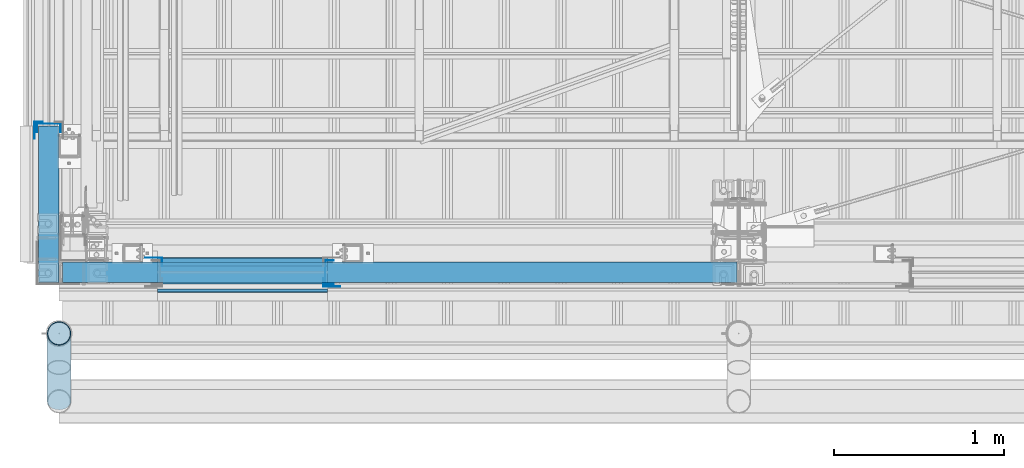
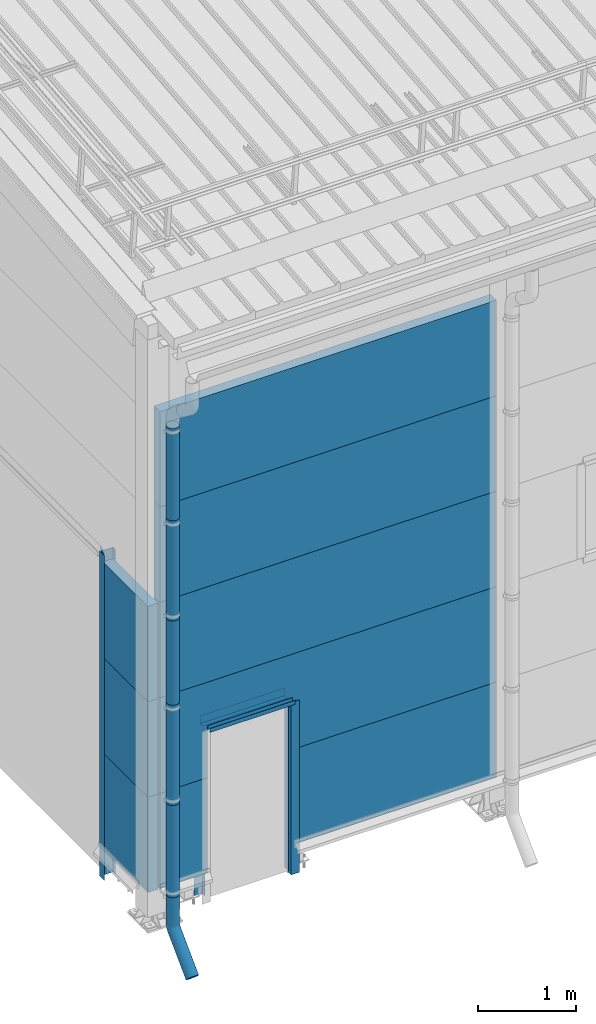
# One storey, part 28 of 709: 23 beams, 1 opening, 23 elements without a shape of their own.
"""IFC4 building model written with IfcOpenShell, lengths in millimetres."""

from ifc_helpers import new_model, entity, si_unit, direction, frame, origin_with_axes, place, context, subcontext, project, spatial, line, indexed_curve, outline, extrude, material, element, aggregate, save


model = new_model("IFC4")

# Units and contexts
model_context = context("Model", 3, precision=0.2, world=origin_with_axes(), true_north=direction((0.0, 1.0)))
body_context = subcontext(model_context, "Body", "Model", "MODEL_VIEW")
ifc_project = project(units=[si_unit("LENGTHUNIT", "METRE", prefix="MILLI"), si_unit("AREAUNIT", "SQUARE_METRE"), si_unit("VOLUMEUNIT", "CUBIC_METRE"), si_unit("MASSUNIT", "GRAM", prefix="KILO"), si_unit("TIMEUNIT", "SECOND"), si_unit("PLANEANGLEUNIT", "RADIAN"), si_unit("SOLIDANGLEUNIT", "STERADIAN"), si_unit("THERMODYNAMICTEMPERATUREUNIT", "DEGREE_CELSIUS"), si_unit("LUMINOUSINTENSITYUNIT", "LUMEN")], contexts=[model_context])

# Site, building, storey
site_placement = place(None, origin_with_axes())
site = spatial("IfcSite", under=ifc_project, at=site_placement, CompositionType="ELEMENT")
building_placement = place(site_placement, origin_with_axes())
building = spatial("IfcBuilding", under=site, at=building_placement, Name="Undefined", CompositionType="ELEMENT")
storey_placement = place(building_placement, origin_with_axes())
storey = spatial("IfcBuildingStorey", under=building, at=storey_placement, Name="Undefined", CompositionType="ELEMENT", Elevation=0.0)

# Assembly, beam, voiding feature
assembly_1_placement = place(storey_placement, frame((20.0, -60.0, 2085.0), z_axis=(0.0, 0.0, -1.0), x_axis=(1.0, 0.0, 0.0)))
assembly_1 = element("IfcElementAssembly", 1, at=assembly_1_placement, inside=storey)
ifc_material_1 = material(Name="Insulation", Category="Insulation")
beam_1_placement = place(assembly_1_placement, origin_with_axes())
beam_1 = element("IfcBeam", 2, at=beam_1_placement, material=ifc_material_1, ObjectType="P-101", context=body_context, shape_type="SolidModel", body=[
    extrude(outline(indexed_curve([(-595.0, -60.0), (595.0, -60.0), (595.0, 60.0), (-595.0, 60.0)], segments=[line(1, 2, 3, 4, 1)])), frame((0.0, 0.0, 0.0), z_axis=(-1.0, 0.0, 0.0), x_axis=(0.0, 0.0, 1.0)), (0.0, 0.0, -1.0), 3970.0),
])
voiding_feature_placement = place(beam_1_placement, frame((560.0, 0.0, -15.0), z_axis=(0.0, 1.0, 0.0), x_axis=(0.0, 0.0, 1.0)))
element("IfcVoidingFeature", 3, at=voiding_feature_placement, cuts=beam_1, Name="opening", PredefinedType="HOLE", context=body_context, shape_type="SolidModel", body=[
    extrude(outline(indexed_curve([(0.0, 0.0), (2150.0, 0.0), (2150.0, 1000.0), (0.0, 1000.0)], segments=[line(1, 2, 3, 4, 1)])), frame((0.0, 0.0, 62.5), z_axis=(0.0, 0.0, 1.0), x_axis=(1.0, 0.0, 0.0)), (0.0, 0.0, -1.0), 125.0),
])
aggregate(assembly_1, [beam_1])

# Assembly, beam
assembly_2_placement = place(storey_placement, frame((20.0, -60.0, 3275.0), z_axis=(0.0, 0.0, -1.0), x_axis=(1.0, 0.0, 0.0)))
assembly_2 = element("IfcElementAssembly", 4, at=assembly_2_placement, inside=storey)
beam_2_placement = place(assembly_2_placement, origin_with_axes())
beam_2 = element("IfcBeam", 5, at=beam_2_placement, material=ifc_material_1, ObjectType="P-102", context=body_context, shape_type="SolidModel", body=[
    extrude(outline(indexed_curve([(-595.0, -60.0), (595.0, -60.0), (595.0, 60.0), (-595.0, 60.0)], segments=[line(1, 2, 3, 4, 1)])), frame((0.0, 0.0, 0.0), z_axis=(-1.0, 0.0, 0.0), x_axis=(0.0, 0.0, 1.0)), (0.0, 0.0, -1.0), 3970.0),
])
aggregate(assembly_2, [beam_2])

assembly_3_placement = place(storey_placement, frame((20.0, -60.0, 4465.0), z_axis=(0.0, 0.0, -1.0), x_axis=(1.0, 0.0, 0.0)))
assembly_3 = element("IfcElementAssembly", 6, at=assembly_3_placement, inside=storey)
beam_3_placement = place(assembly_3_placement, origin_with_axes())
beam_3 = element("IfcBeam", 7, at=beam_3_placement, material=ifc_material_1, ObjectType="P-102", context=body_context, shape_type="SolidModel", body=[
    extrude(outline(indexed_curve([(-595.0, -60.0), (595.0, -60.0), (595.0, 60.0), (-595.0, 60.0)], segments=[line(1, 2, 3, 4, 1)])), frame((0.0, 0.0, 0.0), z_axis=(-1.0, 0.0, 0.0), x_axis=(0.0, 0.0, 1.0)), (0.0, 0.0, -1.0), 3970.0),
])
aggregate(assembly_3, [beam_3])

assembly_4_placement = place(storey_placement, frame((20.0, -60.0, 5655.0), z_axis=(0.0, 0.0, -1.0), x_axis=(1.0, 0.0, 0.0)))
assembly_4 = element("IfcElementAssembly", 8, at=assembly_4_placement, inside=storey)
beam_4_placement = place(assembly_4_placement, origin_with_axes())
beam_4 = element("IfcBeam", 9, at=beam_4_placement, material=ifc_material_1, ObjectType="P-102", context=body_context, shape_type="SolidModel", body=[
    extrude(outline(indexed_curve([(-595.0, -60.0), (595.0, -60.0), (595.0, 60.0), (-595.0, 60.0)], segments=[line(1, 2, 3, 4, 1)])), frame((0.0, 0.0, 0.0), z_axis=(-1.0, 0.0, 0.0), x_axis=(0.0, 0.0, 1.0)), (0.0, 0.0, -1.0), 3970.0),
])
aggregate(assembly_4, [beam_4])

assembly_5_placement = place(storey_placement, frame((20.0, -60.0, 895.0), z_axis=(0.0, 0.0, -1.0), x_axis=(1.0, 0.0, 0.0)))
assembly_5 = element("IfcElementAssembly", 10, at=assembly_5_placement, inside=storey)
beam_5_placement = place(assembly_5_placement, origin_with_axes())
beam_5 = element("IfcBeam", 11, at=beam_5_placement, material=ifc_material_1, ObjectType="P-105", context=body_context, shape_type="SolidModel", body=[
    extrude(outline(indexed_curve([(-595.0, -60.0), (595.0, -60.0), (595.0, 60.0), (-595.0, 60.0)], segments=[line(1, 2, 3, 4, 1)])), frame((0.0, 0.0, 0.0), z_axis=(-1.0, 0.0, 0.0), x_axis=(0.0, 0.0, 1.0)), (0.0, 0.0, -1.0), 560.0),
])
aggregate(assembly_5, [beam_5])

assembly_6_placement = place(storey_placement, frame((1580.0, -60.0, 895.0), z_axis=(0.0, 0.0, -1.0), x_axis=(1.0, 0.0, 0.0)))
assembly_6 = element("IfcElementAssembly", 12, at=assembly_6_placement, inside=storey)
beam_6_placement = place(assembly_6_placement, origin_with_axes())
beam_6 = element("IfcBeam", 13, at=beam_6_placement, material=ifc_material_1, ObjectType="P-106", context=body_context, shape_type="SolidModel", body=[
    extrude(outline(indexed_curve([(-595.0, -60.0), (595.0, -60.0), (595.0, 60.0), (-595.0, 60.0)], segments=[line(1, 2, 3, 4, 1)])), frame((0.0, 0.0, 0.0), z_axis=(-1.0, 0.0, 0.0), x_axis=(0.0, 0.0, 1.0)), (0.0, 0.0, -1.0), 2410.0),
])
aggregate(assembly_6, [beam_6])

assembly_7_placement = place(storey_placement, frame((1580.0, 1.0, 2075.0), z_axis=(0.0, 1.0, 0.0), x_axis=(-1.0, 0.0, 0.0)))
assembly_7 = element("IfcElementAssembly", 14, at=assembly_7_placement, inside=storey)
ifc_material_2 = material(Name="Steel_Undefined", Category="STEEL")
beam_7_placement = place(assembly_7_placement, origin_with_axes())
beam_7 = element("IfcBeam", 15, at=beam_7_placement, material=ifc_material_2, context=body_context, shape_type="SolidModel", body=[
    extrude(outline(indexed_curve([(-25.0, -1.0), (25.0, -1.0), (25.0, 99.0), (23.0, 99.0), (23.0, 1.0), (-25.0, 1.0)], segments=[line(1, 2, 3, 4, 5, 6, 1)])), frame((0.0, 0.0, 0.0), z_axis=(-1.0, 0.0, 0.0), x_axis=(0.0, 0.0, 1.0)), (0.0, 0.0, -1.0), 1000.0),
])
aggregate(assembly_7, [beam_7])

assembly_8_placement = place(storey_placement, frame((580.0, -60.0, 2120.0), z_axis=(0.0, 1.0, 0.0), x_axis=(1.0, 0.0, 0.0)))
assembly_8 = element("IfcElementAssembly", 16, at=assembly_8_placement, inside=storey)
beam_8_placement = place(assembly_8_placement, origin_with_axes())
beam_8 = element("IfcBeam", 17, at=beam_8_placement, material=ifc_material_2, context=body_context, shape_type="SolidModel", body=[
    extrude(outline(indexed_curve([(-70.0, -25.0), (-68.0, -25.0), (-68.0, 23.0), (68.0, 23.0), (68.0, -25.0), (70.0, -25.0), (70.0, 25.0), (-70.0, 25.0)], segments=[line(1, 2, 3, 4, 5, 6, 7, 8, 1)])), frame((0.0, 0.0, 0.0), z_axis=(-1.0, 0.0, 0.0), x_axis=(0.0, 0.0, 1.0)), (0.0, 0.0, -1.0), 1000.0),
])
aggregate(assembly_8, [beam_8])

assembly_9_placement = place(storey_placement, frame((580.0, -169.0, 2090.0), z_axis=(0.0, -1.0, 0.0), x_axis=(1.0, 0.0, 0.0)))
assembly_9 = element("IfcElementAssembly", 18, at=assembly_9_placement, inside=storey)
beam_9_placement = place(assembly_9_placement, origin_with_axes())
beam_9 = element("IfcBeam", 19, at=beam_9_placement, material=ifc_material_2, context=body_context, shape_type="SolidModel", body=[
    extrude(outline(indexed_curve([(-10.0, -1.0), (10.0, -1.0), (10.0, 49.0), (8.0, 49.0), (8.0, 1.0), (-10.0, 1.0)], segments=[line(1, 2, 3, 4, 5, 6, 1)])), frame((0.0, 0.0, 0.0), z_axis=(-1.0, 0.0, 0.0), x_axis=(0.0, 0.0, 1.0)), (0.0, 0.0, -1.0), 1000.0),
])
aggregate(assembly_9, [beam_9])

assembly_10_placement = place(storey_placement, frame((1590.0, -60.0, 2100.0), z_axis=(0.0, 1.0, 0.0), x_axis=(0.0, 0.0, -1.0)))
assembly_10 = element("IfcElementAssembly", 20, at=assembly_10_placement, inside=storey)
beam_10_placement = place(assembly_10_placement, origin_with_axes())
beam_10 = element("IfcBeam", 21, at=beam_10_placement, material=ifc_material_2, context=body_context, shape_type="SolidModel", body=[
    extrude(outline(indexed_curve([(-70.0, -25.0), (-68.0, -25.0), (-68.0, 23.0), (68.0, 23.0), (68.0, -25.0), (70.0, -25.0), (70.0, 25.0), (-70.0, 25.0)], segments=[line(1, 2, 3, 4, 5, 6, 7, 8, 1)])), frame((0.0, 0.0, 0.0), z_axis=(-1.0, 0.0, 0.0), x_axis=(0.0, 0.0, 1.0)), (0.0, 0.0, -1.0), 2150.0),
])
aggregate(assembly_10, [beam_10])

assembly_11_placement = place(storey_placement, frame((1555.0, -119.0, 2100.0), z_axis=(0.0, -1.0, 0.0), x_axis=(0.0, 0.0, -1.0)))
assembly_11 = element("IfcElementAssembly", 22, at=assembly_11_placement, inside=storey)
beam_11_placement = place(assembly_11_placement, origin_with_axes())
beam_11 = element("IfcBeam", 23, at=beam_11_placement, material=ifc_material_2, context=body_context, shape_type="SolidModel", body=[
    extrude(outline(indexed_curve([(-25.0, -1.0), (25.0, -1.0), (25.0, 99.0), (23.0, 99.0), (23.0, 1.0), (-25.0, 1.0)], segments=[line(1, 2, 3, 4, 5, 6, 1)])), frame((0.0, 0.0, 0.0), z_axis=(-1.0, 0.0, 0.0), x_axis=(0.0, 0.0, 1.0)), (0.0, 0.0, -1.0), 2150.0),
])
aggregate(assembly_11, [beam_11])

assembly_12_placement = place(storey_placement, frame((605.0, 1.0, 2100.0), z_axis=(0.0, 1.0, 0.0), x_axis=(0.0, 0.0, -1.0)))
assembly_12 = element("IfcElementAssembly", 24, at=assembly_12_placement, inside=storey)
beam_12_placement = place(assembly_12_placement, origin_with_axes())
beam_12 = element("IfcBeam", 25, at=beam_12_placement, material=ifc_material_2, context=body_context, shape_type="SolidModel", body=[
    extrude(outline(indexed_curve([(-25.0, -1.0), (25.0, -1.0), (25.0, 99.0), (23.0, 99.0), (23.0, 1.0), (-25.0, 1.0)], segments=[line(1, 2, 3, 4, 5, 6, 1)])), frame((0.0, 0.0, 0.0), z_axis=(-1.0, 0.0, 0.0), x_axis=(0.0, 0.0, 1.0)), (0.0, 0.0, -1.0), 2150.0),
])
aggregate(assembly_12, [beam_12])

assembly_13_placement = place(storey_placement, frame((0.0, -420.0, 6276.92297), z_axis=(0.0, 1.0, 0.0), x_axis=(0.0, 0.0, -1.0)))
assembly_13 = element("IfcElementAssembly", 26, at=assembly_13_placement, inside=storey)
beam_13_placement = place(assembly_13_placement, origin_with_axes())
beam_13 = element("IfcBeam", 27, at=beam_13_placement, material=ifc_material_2, ObjectType="614", context=body_context, shape_type="SolidModel", body=[
    extrude(outline(indexed_curve([(70.0, 0.0), (69.61653, 7.31699), (68.47033, 14.55382), (66.57396, 21.63119), (63.94818, 28.47157), (60.62178, 35.0), (56.63119, 41.14497), (52.02014, 46.83914), (46.83914, 52.02014), (41.14497, 56.63119), (35.0, 60.62178), (28.47157, 63.94818), (21.63119, 66.57396), (14.55382, 68.47033), (7.31699, 69.61653), (0.0, 70.0), (-7.31699, 69.61653), (-14.55382, 68.47033), (-21.63119, 66.57396), (-28.47157, 63.94818), (-35.0, 60.62178), (-41.14497, 56.63119), (-46.83914, 52.02014), (-52.02014, 46.83914), (-56.63119, 41.14497), (-60.62178, 35.0), (-63.94818, 28.47157), (-66.57396, 21.63119), (-68.47033, 14.55382), (-69.61653, 7.31699), (-70.0, 0.0), (-69.61653, -7.31699), (-68.47033, -14.55382), (-66.57396, -21.63119), (-63.94818, -28.47157), (-60.62178, -35.0), (-56.63119, -41.14497), (-52.02014, -46.83914), (-46.83914, -52.02014), (-41.14497, -56.63119), (-35.0, -60.62178), (-28.47157, -63.94818), (-21.63119, -66.57396), (-14.55382, -68.47033), (-7.31699, -69.61653), (0.0, -70.0), (7.31699, -69.61653), (14.55382, -68.47033), (21.63119, -66.57396), (28.47157, -63.94818), (35.0, -60.62178), (41.14497, -56.63119), (46.83914, -52.02014), (52.02014, -46.83914), (56.63119, -41.14497), (60.62178, -35.0), (63.94818, -28.47157), (66.57396, -21.63119), (68.47033, -14.55382), (69.61653, -7.31699)], segments=[line(1, 2, 3, 4, 5, 6, 7, 8, 9, 10, 11, 12, 13, 14, 15, 16, 17, 18, 19, 20, 21, 22, 23, 24, 25, 26, 27, 28, 29, 30, 31, 32, 33, 34, 35, 36, 37, 38, 39, 40, 41, 42, 43, 44, 45, 46, 47, 48, 49, 50, 51, 52, 53, 54, 55, 56, 57, 58, 59, 60, 1)]), holes=[indexed_curve([(65.0, 0.0), (64.64392, -6.79435), (63.57959, -13.51426), (61.81867, -20.0861), (59.38045, -26.43788), (56.29165, -32.5), (52.5861, -38.20604), (48.30441, -43.49349), (43.49349, -48.30441), (38.20604, -52.5861), (32.5, -56.29165), (26.43788, -59.38045), (20.0861, -61.81867), (13.51426, -63.57959), (6.79435, -64.64392), (0.0, -65.0), (-6.79435, -64.64392), (-13.51426, -63.57959), (-20.0861, -61.81867), (-26.43788, -59.38045), (-32.5, -56.29165), (-38.20604, -52.5861), (-43.49349, -48.30441), (-48.30441, -43.49349), (-52.5861, -38.20604), (-56.29165, -32.5), (-59.38045, -26.43788), (-61.81867, -20.0861), (-63.57959, -13.51426), (-64.64392, -6.79435), (-65.0, 0.0), (-64.64392, 6.79435), (-63.57959, 13.51426), (-61.81867, 20.0861), (-59.38045, 26.43788), (-56.29165, 32.5), (-52.5861, 38.20604), (-48.30441, 43.49349), (-43.49349, 48.30441), (-38.20604, 52.5861), (-32.5, 56.29165), (-26.43788, 59.38045), (-20.0861, 61.81867), (-13.51426, 63.57959), (-6.79435, 64.64392), (0.0, 65.0), (6.79435, 64.64392), (13.51426, 63.57959), (20.0861, 61.81867), (26.43788, 59.38045), (32.5, 56.29165), (38.20604, 52.5861), (43.49349, 48.30441), (48.30441, 43.49349), (52.5861, 38.20604), (56.29165, 32.5), (59.38045, 26.43788), (61.81867, 20.0861), (63.57959, 13.51426), (64.64392, 6.79435)], segments=[line(1, 2, 3, 4, 5, 6, 7, 8, 9, 10, 11, 12, 13, 14, 15, 16, 17, 18, 19, 20, 21, 22, 23, 24, 25, 26, 27, 28, 29, 30, 31, 32, 33, 34, 35, 36, 37, 38, 39, 40, 41, 42, 43, 44, 45, 46, 47, 48, 49, 50, 51, 52, 53, 54, 55, 56, 57, 58, 59, 60, 1)])]), frame((0.0, 0.0, 0.0), z_axis=(-1.0, 0.0, 0.0), x_axis=(0.0, 0.0, 1.0)), (0.0, 0.0, -1.0), 1250.0),
])
aggregate(assembly_13, [beam_13])

assembly_14_placement = place(storey_placement, frame((0.0, -420.0, 5126.92297), z_axis=(0.0, 1.0, 0.0), x_axis=(0.0, 0.0, -1.0)))
assembly_14 = element("IfcElementAssembly", 28, at=assembly_14_placement, inside=storey)
beam_14_placement = place(assembly_14_placement, origin_with_axes())
beam_14 = element("IfcBeam", 29, at=beam_14_placement, material=ifc_material_2, ObjectType="614", context=body_context, shape_type="SolidModel", body=[
    extrude(outline(indexed_curve([(70.0, 0.0), (69.61653, 7.31699), (68.47033, 14.55382), (66.57396, 21.63119), (63.94818, 28.47157), (60.62178, 35.0), (56.63119, 41.14497), (52.02014, 46.83914), (46.83914, 52.02014), (41.14497, 56.63119), (35.0, 60.62178), (28.47157, 63.94818), (21.63119, 66.57396), (14.55382, 68.47033), (7.31699, 69.61653), (0.0, 70.0), (-7.31699, 69.61653), (-14.55382, 68.47033), (-21.63119, 66.57396), (-28.47157, 63.94818), (-35.0, 60.62178), (-41.14497, 56.63119), (-46.83914, 52.02014), (-52.02014, 46.83914), (-56.63119, 41.14497), (-60.62178, 35.0), (-63.94818, 28.47157), (-66.57396, 21.63119), (-68.47033, 14.55382), (-69.61653, 7.31699), (-70.0, 0.0), (-69.61653, -7.31699), (-68.47033, -14.55382), (-66.57396, -21.63119), (-63.94818, -28.47157), (-60.62178, -35.0), (-56.63119, -41.14497), (-52.02014, -46.83914), (-46.83914, -52.02014), (-41.14497, -56.63119), (-35.0, -60.62178), (-28.47157, -63.94818), (-21.63119, -66.57396), (-14.55382, -68.47033), (-7.31699, -69.61653), (0.0, -70.0), (7.31699, -69.61653), (14.55382, -68.47033), (21.63119, -66.57396), (28.47157, -63.94818), (35.0, -60.62178), (41.14497, -56.63119), (46.83914, -52.02014), (52.02014, -46.83914), (56.63119, -41.14497), (60.62178, -35.0), (63.94818, -28.47157), (66.57396, -21.63119), (68.47033, -14.55382), (69.61653, -7.31699)], segments=[line(1, 2, 3, 4, 5, 6, 7, 8, 9, 10, 11, 12, 13, 14, 15, 16, 17, 18, 19, 20, 21, 22, 23, 24, 25, 26, 27, 28, 29, 30, 31, 32, 33, 34, 35, 36, 37, 38, 39, 40, 41, 42, 43, 44, 45, 46, 47, 48, 49, 50, 51, 52, 53, 54, 55, 56, 57, 58, 59, 60, 1)]), holes=[indexed_curve([(65.0, 0.0), (64.64392, -6.79435), (63.57959, -13.51426), (61.81867, -20.0861), (59.38045, -26.43788), (56.29165, -32.5), (52.5861, -38.20604), (48.30441, -43.49349), (43.49349, -48.30441), (38.20604, -52.5861), (32.5, -56.29165), (26.43788, -59.38045), (20.0861, -61.81867), (13.51426, -63.57959), (6.79435, -64.64392), (0.0, -65.0), (-6.79435, -64.64392), (-13.51426, -63.57959), (-20.0861, -61.81867), (-26.43788, -59.38045), (-32.5, -56.29165), (-38.20604, -52.5861), (-43.49349, -48.30441), (-48.30441, -43.49349), (-52.5861, -38.20604), (-56.29165, -32.5), (-59.38045, -26.43788), (-61.81867, -20.0861), (-63.57959, -13.51426), (-64.64392, -6.79435), (-65.0, 0.0), (-64.64392, 6.79435), (-63.57959, 13.51426), (-61.81867, 20.0861), (-59.38045, 26.43788), (-56.29165, 32.5), (-52.5861, 38.20604), (-48.30441, 43.49349), (-43.49349, 48.30441), (-38.20604, 52.5861), (-32.5, 56.29165), (-26.43788, 59.38045), (-20.0861, 61.81867), (-13.51426, 63.57959), (-6.79435, 64.64392), (0.0, 65.0), (6.79435, 64.64392), (13.51426, 63.57959), (20.0861, 61.81867), (26.43788, 59.38045), (32.5, 56.29165), (38.20604, 52.5861), (43.49349, 48.30441), (48.30441, 43.49349), (52.5861, 38.20604), (56.29165, 32.5), (59.38045, 26.43788), (61.81867, 20.0861), (63.57959, 13.51426), (64.64392, 6.79435)], segments=[line(1, 2, 3, 4, 5, 6, 7, 8, 9, 10, 11, 12, 13, 14, 15, 16, 17, 18, 19, 20, 21, 22, 23, 24, 25, 26, 27, 28, 29, 30, 31, 32, 33, 34, 35, 36, 37, 38, 39, 40, 41, 42, 43, 44, 45, 46, 47, 48, 49, 50, 51, 52, 53, 54, 55, 56, 57, 58, 59, 60, 1)])]), frame((0.0, 0.0, 0.0), z_axis=(-1.0, 0.0, 0.0), x_axis=(0.0, 0.0, 1.0)), (0.0, 0.0, -1.0), 1250.0),
])
aggregate(assembly_14, [beam_14])

assembly_15_placement = place(storey_placement, frame((0.0, -420.0, 3976.92297), z_axis=(0.0, 1.0, 0.0), x_axis=(0.0, 0.0, -1.0)))
assembly_15 = element("IfcElementAssembly", 30, at=assembly_15_placement, inside=storey)
beam_15_placement = place(assembly_15_placement, origin_with_axes())
beam_15 = element("IfcBeam", 31, at=beam_15_placement, material=ifc_material_2, ObjectType="614", context=body_context, shape_type="SolidModel", body=[
    extrude(outline(indexed_curve([(70.0, 0.0), (69.61653, 7.31699), (68.47033, 14.55382), (66.57396, 21.63119), (63.94818, 28.47157), (60.62178, 35.0), (56.63119, 41.14497), (52.02014, 46.83914), (46.83914, 52.02014), (41.14497, 56.63119), (35.0, 60.62178), (28.47157, 63.94818), (21.63119, 66.57396), (14.55382, 68.47033), (7.31699, 69.61653), (0.0, 70.0), (-7.31699, 69.61653), (-14.55382, 68.47033), (-21.63119, 66.57396), (-28.47157, 63.94818), (-35.0, 60.62178), (-41.14497, 56.63119), (-46.83914, 52.02014), (-52.02014, 46.83914), (-56.63119, 41.14497), (-60.62178, 35.0), (-63.94818, 28.47157), (-66.57396, 21.63119), (-68.47033, 14.55382), (-69.61653, 7.31699), (-70.0, 0.0), (-69.61653, -7.31699), (-68.47033, -14.55382), (-66.57396, -21.63119), (-63.94818, -28.47157), (-60.62178, -35.0), (-56.63119, -41.14497), (-52.02014, -46.83914), (-46.83914, -52.02014), (-41.14497, -56.63119), (-35.0, -60.62178), (-28.47157, -63.94818), (-21.63119, -66.57396), (-14.55382, -68.47033), (-7.31699, -69.61653), (0.0, -70.0), (7.31699, -69.61653), (14.55382, -68.47033), (21.63119, -66.57396), (28.47157, -63.94818), (35.0, -60.62178), (41.14497, -56.63119), (46.83914, -52.02014), (52.02014, -46.83914), (56.63119, -41.14497), (60.62178, -35.0), (63.94818, -28.47157), (66.57396, -21.63119), (68.47033, -14.55382), (69.61653, -7.31699)], segments=[line(1, 2, 3, 4, 5, 6, 7, 8, 9, 10, 11, 12, 13, 14, 15, 16, 17, 18, 19, 20, 21, 22, 23, 24, 25, 26, 27, 28, 29, 30, 31, 32, 33, 34, 35, 36, 37, 38, 39, 40, 41, 42, 43, 44, 45, 46, 47, 48, 49, 50, 51, 52, 53, 54, 55, 56, 57, 58, 59, 60, 1)]), holes=[indexed_curve([(65.0, 0.0), (64.64392, -6.79435), (63.57959, -13.51426), (61.81867, -20.0861), (59.38045, -26.43788), (56.29165, -32.5), (52.5861, -38.20604), (48.30441, -43.49349), (43.49349, -48.30441), (38.20604, -52.5861), (32.5, -56.29165), (26.43788, -59.38045), (20.0861, -61.81867), (13.51426, -63.57959), (6.79435, -64.64392), (0.0, -65.0), (-6.79435, -64.64392), (-13.51426, -63.57959), (-20.0861, -61.81867), (-26.43788, -59.38045), (-32.5, -56.29165), (-38.20604, -52.5861), (-43.49349, -48.30441), (-48.30441, -43.49349), (-52.5861, -38.20604), (-56.29165, -32.5), (-59.38045, -26.43788), (-61.81867, -20.0861), (-63.57959, -13.51426), (-64.64392, -6.79435), (-65.0, 0.0), (-64.64392, 6.79435), (-63.57959, 13.51426), (-61.81867, 20.0861), (-59.38045, 26.43788), (-56.29165, 32.5), (-52.5861, 38.20604), (-48.30441, 43.49349), (-43.49349, 48.30441), (-38.20604, 52.5861), (-32.5, 56.29165), (-26.43788, 59.38045), (-20.0861, 61.81867), (-13.51426, 63.57959), (-6.79435, 64.64392), (0.0, 65.0), (6.79435, 64.64392), (13.51426, 63.57959), (20.0861, 61.81867), (26.43788, 59.38045), (32.5, 56.29165), (38.20604, 52.5861), (43.49349, 48.30441), (48.30441, 43.49349), (52.5861, 38.20604), (56.29165, 32.5), (59.38045, 26.43788), (61.81867, 20.0861), (63.57959, 13.51426), (64.64392, 6.79435)], segments=[line(1, 2, 3, 4, 5, 6, 7, 8, 9, 10, 11, 12, 13, 14, 15, 16, 17, 18, 19, 20, 21, 22, 23, 24, 25, 26, 27, 28, 29, 30, 31, 32, 33, 34, 35, 36, 37, 38, 39, 40, 41, 42, 43, 44, 45, 46, 47, 48, 49, 50, 51, 52, 53, 54, 55, 56, 57, 58, 59, 60, 1)])]), frame((0.0, 0.0, 0.0), z_axis=(-1.0, 0.0, 0.0), x_axis=(0.0, 0.0, 1.0)), (0.0, 0.0, -1.0), 1250.0),
])
aggregate(assembly_15, [beam_15])

assembly_16_placement = place(storey_placement, frame((0.0, -420.0, 2826.92297), z_axis=(0.0, 1.0, 0.0), x_axis=(0.0, 0.0, -1.0)))
assembly_16 = element("IfcElementAssembly", 32, at=assembly_16_placement, inside=storey)
beam_16_placement = place(assembly_16_placement, origin_with_axes())
beam_16 = element("IfcBeam", 33, at=beam_16_placement, material=ifc_material_2, ObjectType="614", context=body_context, shape_type="SolidModel", body=[
    extrude(outline(indexed_curve([(70.0, 0.0), (69.61653, 7.31699), (68.47033, 14.55382), (66.57396, 21.63119), (63.94818, 28.47157), (60.62178, 35.0), (56.63119, 41.14497), (52.02014, 46.83914), (46.83914, 52.02014), (41.14497, 56.63119), (35.0, 60.62178), (28.47157, 63.94818), (21.63119, 66.57396), (14.55382, 68.47033), (7.31699, 69.61653), (0.0, 70.0), (-7.31699, 69.61653), (-14.55382, 68.47033), (-21.63119, 66.57396), (-28.47157, 63.94818), (-35.0, 60.62178), (-41.14497, 56.63119), (-46.83914, 52.02014), (-52.02014, 46.83914), (-56.63119, 41.14497), (-60.62178, 35.0), (-63.94818, 28.47157), (-66.57396, 21.63119), (-68.47033, 14.55382), (-69.61653, 7.31699), (-70.0, 0.0), (-69.61653, -7.31699), (-68.47033, -14.55382), (-66.57396, -21.63119), (-63.94818, -28.47157), (-60.62178, -35.0), (-56.63119, -41.14497), (-52.02014, -46.83914), (-46.83914, -52.02014), (-41.14497, -56.63119), (-35.0, -60.62178), (-28.47157, -63.94818), (-21.63119, -66.57396), (-14.55382, -68.47033), (-7.31699, -69.61653), (0.0, -70.0), (7.31699, -69.61653), (14.55382, -68.47033), (21.63119, -66.57396), (28.47157, -63.94818), (35.0, -60.62178), (41.14497, -56.63119), (46.83914, -52.02014), (52.02014, -46.83914), (56.63119, -41.14497), (60.62178, -35.0), (63.94818, -28.47157), (66.57396, -21.63119), (68.47033, -14.55382), (69.61653, -7.31699)], segments=[line(1, 2, 3, 4, 5, 6, 7, 8, 9, 10, 11, 12, 13, 14, 15, 16, 17, 18, 19, 20, 21, 22, 23, 24, 25, 26, 27, 28, 29, 30, 31, 32, 33, 34, 35, 36, 37, 38, 39, 40, 41, 42, 43, 44, 45, 46, 47, 48, 49, 50, 51, 52, 53, 54, 55, 56, 57, 58, 59, 60, 1)]), holes=[indexed_curve([(65.0, 0.0), (64.64392, -6.79435), (63.57959, -13.51426), (61.81867, -20.0861), (59.38045, -26.43788), (56.29165, -32.5), (52.5861, -38.20604), (48.30441, -43.49349), (43.49349, -48.30441), (38.20604, -52.5861), (32.5, -56.29165), (26.43788, -59.38045), (20.0861, -61.81867), (13.51426, -63.57959), (6.79435, -64.64392), (0.0, -65.0), (-6.79435, -64.64392), (-13.51426, -63.57959), (-20.0861, -61.81867), (-26.43788, -59.38045), (-32.5, -56.29165), (-38.20604, -52.5861), (-43.49349, -48.30441), (-48.30441, -43.49349), (-52.5861, -38.20604), (-56.29165, -32.5), (-59.38045, -26.43788), (-61.81867, -20.0861), (-63.57959, -13.51426), (-64.64392, -6.79435), (-65.0, 0.0), (-64.64392, 6.79435), (-63.57959, 13.51426), (-61.81867, 20.0861), (-59.38045, 26.43788), (-56.29165, 32.5), (-52.5861, 38.20604), (-48.30441, 43.49349), (-43.49349, 48.30441), (-38.20604, 52.5861), (-32.5, 56.29165), (-26.43788, 59.38045), (-20.0861, 61.81867), (-13.51426, 63.57959), (-6.79435, 64.64392), (0.0, 65.0), (6.79435, 64.64392), (13.51426, 63.57959), (20.0861, 61.81867), (26.43788, 59.38045), (32.5, 56.29165), (38.20604, 52.5861), (43.49349, 48.30441), (48.30441, 43.49349), (52.5861, 38.20604), (56.29165, 32.5), (59.38045, 26.43788), (61.81867, 20.0861), (63.57959, 13.51426), (64.64392, 6.79435)], segments=[line(1, 2, 3, 4, 5, 6, 7, 8, 9, 10, 11, 12, 13, 14, 15, 16, 17, 18, 19, 20, 21, 22, 23, 24, 25, 26, 27, 28, 29, 30, 31, 32, 33, 34, 35, 36, 37, 38, 39, 40, 41, 42, 43, 44, 45, 46, 47, 48, 49, 50, 51, 52, 53, 54, 55, 56, 57, 58, 59, 60, 1)])]), frame((0.0, 0.0, 0.0), z_axis=(-1.0, 0.0, 0.0), x_axis=(0.0, 0.0, 1.0)), (0.0, 0.0, -1.0), 1250.0),
])
aggregate(assembly_16, [beam_16])

assembly_17_placement = place(storey_placement, frame((0.0, -420.0, 1676.92297), z_axis=(0.0, 1.0, 0.0), x_axis=(0.0, 0.0, -1.0)))
assembly_17 = element("IfcElementAssembly", 34, at=assembly_17_placement, inside=storey)
beam_17_placement = place(assembly_17_placement, origin_with_axes())
beam_17 = element("IfcBeam", 35, at=beam_17_placement, material=ifc_material_2, ObjectType="614", context=body_context, shape_type="SolidModel", body=[
    extrude(outline(indexed_curve([(70.0, 0.0), (69.61653, 7.31699), (68.47033, 14.55382), (66.57396, 21.63119), (63.94818, 28.47157), (60.62178, 35.0), (56.63119, 41.14497), (52.02014, 46.83914), (46.83914, 52.02014), (41.14497, 56.63119), (35.0, 60.62178), (28.47157, 63.94818), (21.63119, 66.57396), (14.55382, 68.47033), (7.31699, 69.61653), (0.0, 70.0), (-7.31699, 69.61653), (-14.55382, 68.47033), (-21.63119, 66.57396), (-28.47157, 63.94818), (-35.0, 60.62178), (-41.14497, 56.63119), (-46.83914, 52.02014), (-52.02014, 46.83914), (-56.63119, 41.14497), (-60.62178, 35.0), (-63.94818, 28.47157), (-66.57396, 21.63119), (-68.47033, 14.55382), (-69.61653, 7.31699), (-70.0, 0.0), (-69.61653, -7.31699), (-68.47033, -14.55382), (-66.57396, -21.63119), (-63.94818, -28.47157), (-60.62178, -35.0), (-56.63119, -41.14497), (-52.02014, -46.83914), (-46.83914, -52.02014), (-41.14497, -56.63119), (-35.0, -60.62178), (-28.47157, -63.94818), (-21.63119, -66.57396), (-14.55382, -68.47033), (-7.31699, -69.61653), (0.0, -70.0), (7.31699, -69.61653), (14.55382, -68.47033), (21.63119, -66.57396), (28.47157, -63.94818), (35.0, -60.62178), (41.14497, -56.63119), (46.83914, -52.02014), (52.02014, -46.83914), (56.63119, -41.14497), (60.62178, -35.0), (63.94818, -28.47157), (66.57396, -21.63119), (68.47033, -14.55382), (69.61653, -7.31699)], segments=[line(1, 2, 3, 4, 5, 6, 7, 8, 9, 10, 11, 12, 13, 14, 15, 16, 17, 18, 19, 20, 21, 22, 23, 24, 25, 26, 27, 28, 29, 30, 31, 32, 33, 34, 35, 36, 37, 38, 39, 40, 41, 42, 43, 44, 45, 46, 47, 48, 49, 50, 51, 52, 53, 54, 55, 56, 57, 58, 59, 60, 1)]), holes=[indexed_curve([(65.0, 0.0), (64.64392, -6.79435), (63.57959, -13.51426), (61.81867, -20.0861), (59.38045, -26.43788), (56.29165, -32.5), (52.5861, -38.20604), (48.30441, -43.49349), (43.49349, -48.30441), (38.20604, -52.5861), (32.5, -56.29165), (26.43788, -59.38045), (20.0861, -61.81867), (13.51426, -63.57959), (6.79435, -64.64392), (0.0, -65.0), (-6.79435, -64.64392), (-13.51426, -63.57959), (-20.0861, -61.81867), (-26.43788, -59.38045), (-32.5, -56.29165), (-38.20604, -52.5861), (-43.49349, -48.30441), (-48.30441, -43.49349), (-52.5861, -38.20604), (-56.29165, -32.5), (-59.38045, -26.43788), (-61.81867, -20.0861), (-63.57959, -13.51426), (-64.64392, -6.79435), (-65.0, 0.0), (-64.64392, 6.79435), (-63.57959, 13.51426), (-61.81867, 20.0861), (-59.38045, 26.43788), (-56.29165, 32.5), (-52.5861, 38.20604), (-48.30441, 43.49349), (-43.49349, 48.30441), (-38.20604, 52.5861), (-32.5, 56.29165), (-26.43788, 59.38045), (-20.0861, 61.81867), (-13.51426, 63.57959), (-6.79435, 64.64392), (0.0, 65.0), (6.79435, 64.64392), (13.51426, 63.57959), (20.0861, 61.81867), (26.43788, 59.38045), (32.5, 56.29165), (38.20604, 52.5861), (43.49349, 48.30441), (48.30441, 43.49349), (52.5861, 38.20604), (56.29165, 32.5), (59.38045, 26.43788), (61.81867, 20.0861), (63.57959, 13.51426), (64.64392, 6.79435)], segments=[line(1, 2, 3, 4, 5, 6, 7, 8, 9, 10, 11, 12, 13, 14, 15, 16, 17, 18, 19, 20, 21, 22, 23, 24, 25, 26, 27, 28, 29, 30, 31, 32, 33, 34, 35, 36, 37, 38, 39, 40, 41, 42, 43, 44, 45, 46, 47, 48, 49, 50, 51, 52, 53, 54, 55, 56, 57, 58, 59, 60, 1)])]), frame((0.0, 0.0, 0.0), z_axis=(-1.0, 0.0, 0.0), x_axis=(0.0, 0.0, 1.0)), (0.0, 0.0, -1.0), 1250.0),
])
aggregate(assembly_17, [beam_17])

assembly_18_placement = place(storey_placement, frame((0.0, -420.0, 526.92297), z_axis=(-1.0, 0.0, 0.0), x_axis=(0.0, 0.0, -1.0)))
assembly_18 = element("IfcElementAssembly", 36, at=assembly_18_placement, inside=storey)
beam_18_placement = place(assembly_18_placement, origin_with_axes())
beam_18 = element("IfcBeam", 37, at=beam_18_placement, material=ifc_material_2, ObjectType="617", context=body_context, shape_type="SolidModel", body=[
    entity("IfcSweptDiskSolid", entity("IfcIndexedPolyCurve", entity("IfcCartesianPointList3D", [[0.0, 0.0, 0.0], [448.2233, 0.0, 0.0], [496.05873, 9.51506, 0.0], [536.61165, 36.61165, 0.0], [900.0, 400.0, 0.0]]), [entity("IfcLineIndex", [1, 2]), entity("IfcArcIndex", [2, 3, 4]), entity("IfcLineIndex", [4, 5])]), 70.0, 65.0),
])
aggregate(assembly_18, [beam_18])

assembly_19_placement = place(storey_placement, frame((-60.0, -120.0, 895.0), z_axis=(0.0, 0.0, -1.0), x_axis=(0.0, 1.0, 0.0)))
assembly_19 = element("IfcElementAssembly", 38, at=assembly_19_placement, inside=storey)
beam_19_placement = place(assembly_19_placement, origin_with_axes())
beam_19 = element("IfcBeam", 39, at=beam_19_placement, material=ifc_material_1, ObjectType="P-133", context=body_context, shape_type="SolidModel", body=[
    extrude(outline(indexed_curve([(-595.0, -60.0), (595.0, -60.0), (595.0, 60.0), (-595.0, 60.0)], segments=[line(1, 2, 3, 4, 1)])), frame((0.0, 0.0, 0.0), z_axis=(-1.0, 0.0, 0.0), x_axis=(0.0, 0.0, 1.0)), (0.0, 0.0, -1.0), 920.0),
])
aggregate(assembly_19, [beam_19])

assembly_20_placement = place(storey_placement, frame((-60.0, -120.0, 2085.0), z_axis=(0.0, 0.0, -1.0), x_axis=(0.0, 1.0, 0.0)))
assembly_20 = element("IfcElementAssembly", 40, at=assembly_20_placement, inside=storey)
beam_20_placement = place(assembly_20_placement, origin_with_axes())
beam_20 = element("IfcBeam", 41, at=beam_20_placement, material=ifc_material_1, ObjectType="P-133", context=body_context, shape_type="SolidModel", body=[
    extrude(outline(indexed_curve([(-595.0, -60.0), (595.0, -60.0), (595.0, 60.0), (-595.0, 60.0)], segments=[line(1, 2, 3, 4, 1)])), frame((0.0, 0.0, 0.0), z_axis=(-1.0, 0.0, 0.0), x_axis=(0.0, 0.0, 1.0)), (0.0, 0.0, -1.0), 920.0),
])
aggregate(assembly_20, [beam_20])

assembly_21_placement = place(storey_placement, frame((-60.0, -120.0, 3275.0), z_axis=(0.0, 0.0, -1.0), x_axis=(0.0, 1.0, 0.0)))
assembly_21 = element("IfcElementAssembly", 42, at=assembly_21_placement, inside=storey)
beam_21_placement = place(assembly_21_placement, origin_with_axes())
beam_21 = element("IfcBeam", 43, at=beam_21_placement, material=ifc_material_1, ObjectType="P-133", context=body_context, shape_type="SolidModel", body=[
    extrude(outline(indexed_curve([(-595.0, -60.0), (595.0, -60.0), (595.0, 60.0), (-595.0, 60.0)], segments=[line(1, 2, 3, 4, 1)])), frame((0.0, 0.0, 0.0), z_axis=(-1.0, 0.0, 0.0), x_axis=(0.0, 0.0, 1.0)), (0.0, 0.0, -1.0), 920.0),
])
aggregate(assembly_21, [beam_21])

assembly_22_placement = place(storey_placement, frame((-60.0, 790.0, 4000.0), z_axis=(1.0, 0.0, 0.0), x_axis=(0.0, 0.0, -1.0)))
assembly_22 = element("IfcElementAssembly", 44, at=assembly_22_placement, inside=storey)
beam_22_placement = place(assembly_22_placement, origin_with_axes())
beam_22 = element("IfcBeam", 45, at=beam_22_placement, material=ifc_material_2, context=body_context, shape_type="SolidModel", body=[
    extrude(outline(indexed_curve([(-70.0, -25.0), (-68.0, -25.0), (-68.0, 23.0), (68.0, 23.0), (68.0, -25.0), (70.0, -25.0), (70.0, 25.0), (-70.0, 25.0)], segments=[line(1, 2, 3, 4, 5, 6, 7, 8, 1)])), frame((0.0, 0.0, 0.0), z_axis=(-1.0, 0.0, 0.0), x_axis=(0.0, 0.0, 1.0)), (0.0, 0.0, -1.0), 4050.0),
])
aggregate(assembly_22, [beam_22])

assembly_23_placement = place(storey_placement, frame((-121.0, 825.0, 4000.0), z_axis=(-1.0, 0.0, 0.0), x_axis=(0.0, 0.0, -1.0)))
assembly_23 = element("IfcElementAssembly", 46, at=assembly_23_placement, inside=storey)
beam_23_placement = place(assembly_23_placement, origin_with_axes())
beam_23 = element("IfcBeam", 47, at=beam_23_placement, material=ifc_material_2, context=body_context, shape_type="SolidModel", body=[
    extrude(outline(indexed_curve([(-25.0, -1.0), (25.0, -1.0), (25.0, 99.0), (23.0, 99.0), (23.0, 1.0), (-25.0, 1.0)], segments=[line(1, 2, 3, 4, 5, 6, 1)])), frame((0.0, 0.0, 0.0), z_axis=(-1.0, 0.0, 0.0), x_axis=(0.0, 0.0, 1.0)), (0.0, 0.0, -1.0), 4050.0),
])
aggregate(assembly_23, [beam_23])

save(model, "model.ifc")
